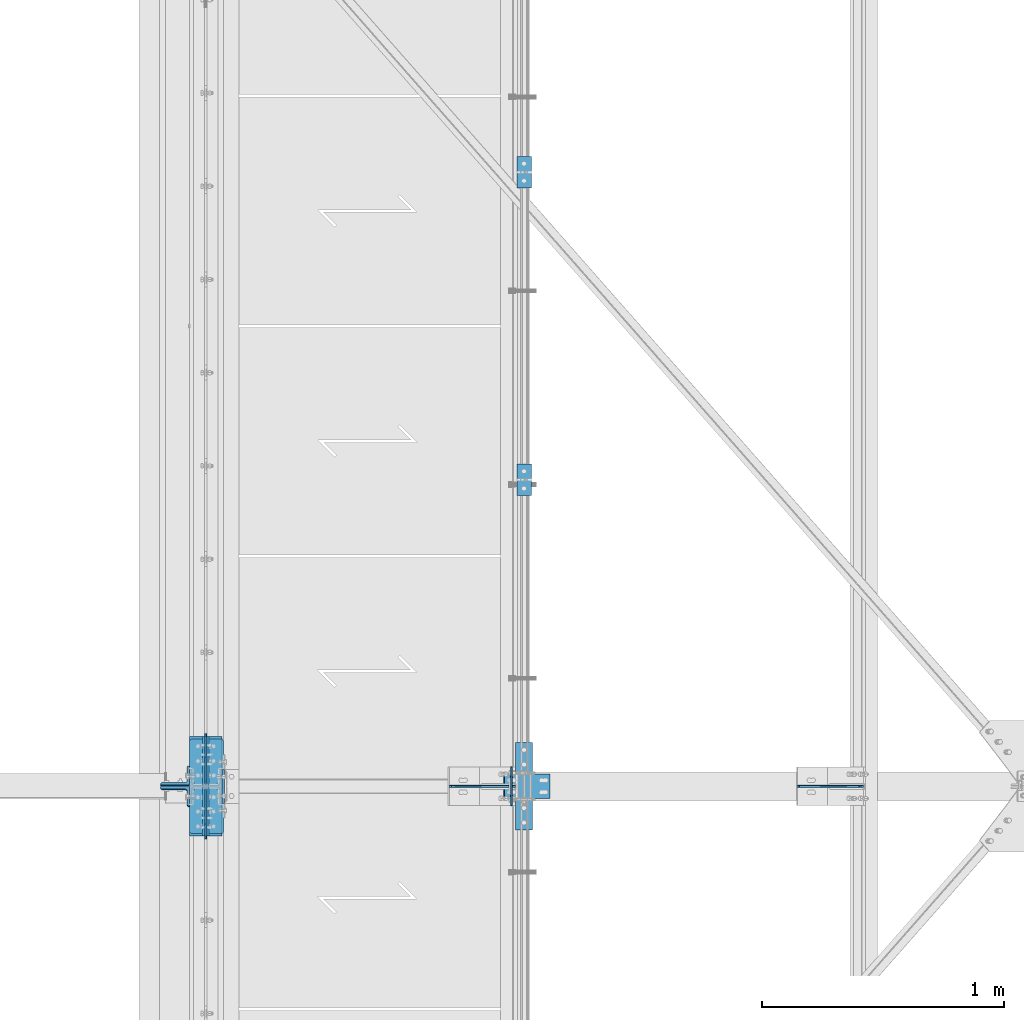
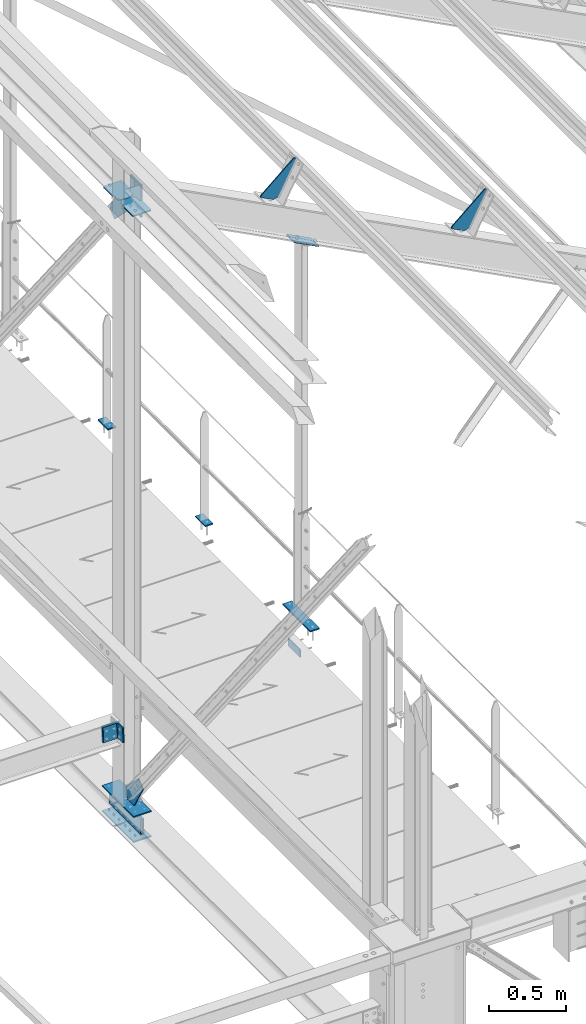
# One storey, part 71 of 496: 15 beams, 3 members, 12 elements without a shape of their own.
"""IFC2X3 building model written with IfcOpenShell, lengths in millimetres."""

from ifc_helpers import new_model, si_unit, frame, frame_2d, origin_with_axes, origin_2d_with_axis, place, context, subcontext, project, spatial, polyline, circle_curve, parameter, trimmed, segment, composite_curve, rectangle, l_section, outline, extrude, material, type_object, element, aggregate, save


model = new_model("IFC2X3")

# Units and contexts
model_context = context("Model", 3, precision=1e-05, world=origin_with_axes())
body_context = subcontext(model_context, "Body", "Model", "MODEL_VIEW")
ifc_project = project(units=[si_unit("LENGTHUNIT", "METRE", prefix="MILLI"), si_unit("AREAUNIT", "SQUARE_METRE"), si_unit("VOLUMEUNIT", "CUBIC_METRE"), si_unit("MASSUNIT", "GRAM", prefix="KILO"), si_unit("TIMEUNIT", "SECOND"), si_unit("PLANEANGLEUNIT", "RADIAN"), si_unit("SOLIDANGLEUNIT", "STERADIAN"), si_unit("THERMODYNAMICTEMPERATUREUNIT", "DEGREE_CELSIUS"), si_unit("LUMINOUSINTENSITYUNIT", "LUMEN")], contexts=[model_context])

# Site, building, storey
site_placement = place(None, origin_with_axes())
site = spatial("IfcSite", under=ifc_project, at=site_placement, CompositionType="ELEMENT")
building_placement = place(site_placement, origin_with_axes())
building = spatial("IfcBuilding", under=site, at=building_placement, Name="Undefined", CompositionType="ELEMENT")
storey_placement = place(building_placement, origin_with_axes())
storey = spatial("IfcBuildingStorey", under=building, at=storey_placement, Name="Undefined", CompositionType="ELEMENT", Elevation=0.0)

# Assembly, beams
assembly_1_placement = place(storey_placement, origin_with_axes())
assembly_1 = element("IfcElementAssembly", 1, at=assembly_1_placement, inside=storey, Name="MAIN COURANTE", AssemblyPlace="NOTDEFINED", PredefinedType="NOTDEFINED")
ifc_material = material(Name="Undefined/S235-E24")
beam_type_1 = type_object("IfcBeamType", PredefinedType="NOTDEFINED")
beam_1_placement = place(assembly_1_placement, frame((13993.9998863, 5130.00344717353, 8245.00000549095), z_axis=(-1.0, 0.0, 0.0), x_axis=(0.0, -1.0, 0.0)))
beam_1 = element("IfcBeam", 2, at=beam_1_placement, type_object=beam_type_1, material=ifc_material, context=body_context, shape_type="SweptSolid", body=[
    extrude(rectangle(XDim=10.0, YDim=60.0, at=origin_2d_with_axis()), frame((130.0, 0.0, 0.0), z_axis=(-1.0, 0.0, 0.0), x_axis=(0.0, -1.0, 0.0)), (0.0, 0.0, 1.0), 130.0),
])
beam_2_placement = place(assembly_1_placement, frame((13993.9998873551, 6400.00344717353, 8245.00000462038), z_axis=(-1.0, 0.0, 0.0), x_axis=(0.0, -1.0, 0.0)))
beam_2 = element("IfcBeam", 3, at=beam_2_placement, type_object=beam_type_1, material=ifc_material, context=body_context, shape_type="SweptSolid", body=[
    extrude(rectangle(XDim=10.0, YDim=60.0, at=origin_2d_with_axis()), frame((130.0, 0.0, 0.0), z_axis=(-1.0, 0.0, 0.0), x_axis=(0.0, -1.0, 0.0)), (0.0, 0.0, 1.0), 130.0),
])
aggregate(assembly_1, [beam_1, beam_2])

# Assembly, beam
assembly_2_placement = place(storey_placement, origin_with_axes())
assembly_2 = element("IfcElementAssembly", 4, at=assembly_2_placement, inside=storey, Name="SHED", AssemblyPlace="NOTDEFINED", PredefinedType="NOTDEFINED")
beam_type_2 = type_object("IfcBeamType", PredefinedType="NOTDEFINED")
beam_3_placement = place(assembly_2_placement, frame((15395.0613651869, 3800.0, 11158.7378432617), z_axis=(0.0, -1.0, 0.0), x_axis=(-0.886081824994261, -1.3000000762986e-08, 0.46352885499701)))
beam_3 = element("IfcBeam", 5, at=beam_3_placement, type_object=beam_type_2, material=ifc_material, context=body_context, shape_type="SweptSolid", body=[
    extrude(outline(polyline([(0.0, 0.0), (20.0, 0.0), (140.000030519084, 299.999999999567), (140.000030519153, 319.999999999545), (30.0000147075953, 319.999999999634), (0.0, 290.0), (0.0, 0.0)])), frame((0.0, 0.0, -4.0), z_axis=(0.0, 0.0, 1.0), x_axis=(1.0, 0.0, 0.0)), (0.0, 0.0, 1.0), 8.0),
])
aggregate(assembly_2, [beam_3])

assembly_3_placement = place(storey_placement, origin_with_axes())
assembly_3 = element("IfcElementAssembly", 6, at=assembly_3_placement, inside=storey, Name="SHED", AssemblyPlace="NOTDEFINED", PredefinedType="NOTDEFINED")
beam_4_placement = place(assembly_3_placement, frame((13957.7613225854, 3800.0, 11910.6201334583), z_axis=(0.0, -1.0, 0.0), x_axis=(-0.886081824994261, -1.3000000762986e-08, 0.46352885499701)))
beam_4 = element("IfcBeam", 7, at=beam_4_placement, type_object=beam_type_2, material=ifc_material, context=body_context, shape_type="SweptSolid", body=[
    extrude(outline(polyline([(0.0, 0.0), (20.0, 0.0), (140.000030519084, 299.999999999567), (140.000030519153, 319.999999999545), (30.0000147075953, 319.999999999634), (0.0, 290.0), (0.0, 0.0)])), frame((0.0, 0.0, -4.0), z_axis=(0.0, 0.0, 1.0), x_axis=(1.0, 0.0, 0.0)), (0.0, 0.0, 1.0), 8.0),
])
aggregate(assembly_3, [beam_4])

assembly_4_placement = place(storey_placement, origin_with_axes())
assembly_4 = element("IfcElementAssembly", 8, at=assembly_4_placement, inside=storey, AssemblyPlace="NOTDEFINED", PredefinedType="NOTDEFINED")
beam_type_3 = type_object("IfcBeamType", PredefinedType="NOTDEFINED")
beam_5_placement = place(assembly_4_placement, frame((12680.0, 4005.00000000017, 7055.00000000032), z_axis=(1.0, 0.0, 0.0), x_axis=(0.0, -1.0, 0.0)))
beam_5 = element("IfcBeam", 9, at=beam_5_placement, type_object=beam_type_3, material=ifc_material, context=body_context, shape_type="SweptSolid", body=[
    extrude(rectangle(XDim=10.0, YDim=133.0, at=origin_2d_with_axis()), frame((410.0, 0.0, 0.0), z_axis=(-1.0, 0.0, 0.0), x_axis=(0.0, -1.0, 0.0)), (0.0, 0.0, 1.0), 410.0),
])
aggregate(assembly_4, [beam_5])

assembly_5_placement = place(storey_placement, origin_with_axes())
assembly_5 = element("IfcElementAssembly", 10, at=assembly_5_placement, inside=storey, Name="MONTANT", AssemblyPlace="NOTDEFINED", PredefinedType="NOTDEFINED")
beam_6_placement = place(assembly_5_placement, frame((12680.0, 4005.00000000017, 7255.00000000032), z_axis=(1.0, 0.0, 0.0), x_axis=(0.0, -1.0, 0.0)))
beam_6 = element("IfcBeam", 11, at=beam_6_placement, type_object=beam_type_3, material=ifc_material, context=body_context, shape_type="SweptSolid", body=[
    extrude(rectangle(XDim=10.0, YDim=133.0, at=origin_2d_with_axis()), frame((410.0, 0.0, 0.0), z_axis=(-1.0, 0.0, 0.0), x_axis=(0.0, -1.0, 0.0)), (0.0, 0.0, 1.0), 410.0),
])

# Assembly, member
assembly_6_placement = place(storey_placement, origin_with_axes())
assembly_6 = element("IfcElementAssembly", 12, at=assembly_6_placement, inside=storey, AssemblyPlace="NOTDEFINED", PredefinedType="NOTDEFINED")
member_type_1 = type_object("IfcMemberType", PredefinedType="NOTDEFINED")
member_1_placement = place(assembly_6_placement, frame((13911.9348604257, 3800.00000001334, 11285.668922065), z_axis=(0.0, -1.0, 0.0), x_axis=(0.886081856298361, 3.500000375794e-08, -0.463528795156082)))
member_1 = element("IfcMember", 13, at=member_1_placement, type_object=member_type_1, material=ifc_material, context=body_context, shape_type="SweptSolid", body=[
    extrude(rectangle(XDim=10.0, YDim=100.0, at=origin_2d_with_axis()), frame((210.000000000491, 0.0, 1.81898940354586e-12), z_axis=(-1.0, 0.0, 0.0), x_axis=(0.0, -1.0, 0.0)), (0.0, 0.0, 1.0), 210.0),
])

# Assembly, beam
assembly_7_placement = place(storey_placement, origin_with_axes())
assembly_7 = element("IfcElementAssembly", 14, at=assembly_7_placement, inside=storey, AssemblyPlace="NOTDEFINED", PredefinedType="NOTDEFINED")
beam_type_4 = type_object("IfcBeamType", PredefinedType="NOTDEFINED")
beam_7_placement = place(assembly_7_placement, frame((13942.9998855295, 3720.0, 7985.0), z_axis=(-1.0, 0.0, 0.0), x_axis=(0.0, 0.0, 1.0)))
beam_7 = element("IfcBeam", 15, at=beam_7_placement, type_object=beam_type_4, material=ifc_material, context=body_context, shape_type="SweptSolid", body=[
    extrude(outline(polyline([(0.0, 0.0), (60.0, 0.0), (60.0, 159.999984741211), (0.0, 159.999984741211), (0.0, 0.0)])), frame((0.0, 0.0, -3.0), z_axis=(0.0, 0.0, 1.0), x_axis=(1.0, 0.0, 0.0)), (0.0, 0.0, 1.0), 6.0),
])
aggregate(assembly_7, [beam_7])

# Beam
beam_type_5 = type_object("IfcBeamType", PredefinedType="NOTDEFINED")
beam_8_placement = place(assembly_6_placement, frame((13993.9998855295, 3980.00010616247, 8245.00000367738), z_axis=(1.0, 0.0, 0.0), x_axis=(0.0, -1.0, 0.0)))
beam_8 = element("IfcBeam", 16, at=beam_8_placement, type_object=beam_type_5, material=ifc_material, context=body_context, shape_type="SweptSolid", body=[
    extrude(rectangle(XDim=10.0, YDim=70.0, at=origin_2d_with_axis()), frame((360.000000000004, 0.0, 0.0), z_axis=(-1.0, 0.0, 0.0), x_axis=(0.0, -1.0, 0.0)), (0.0, 0.0, 1.0), 360.0),
])

aggregate(assembly_6, [member_1, beam_8])

# Assembly, beam
assembly_8_placement = place(storey_placement, origin_with_axes())
assembly_8 = element("IfcElementAssembly", 17, at=assembly_8_placement, inside=storey, Name="TRAVERSE SHED", AssemblyPlace="NOTDEFINED", PredefinedType="NOTDEFINED")
beam_type_6 = type_object("IfcBeamType", PredefinedType="NOTDEFINED")
beam_9_placement = place(assembly_8_placement, frame((12751.5, 3800.0, 12161.0697488335), z_axis=(0.0, -1.0, 0.0), x_axis=(0.0, 0.0, -1.0)))
beam_9 = element("IfcBeam", 18, at=beam_9_placement, type_object=beam_type_6, material=ifc_material, context=body_context, shape_type="SweptSolid", body=[
    extrude(rectangle(XDim=10.0, YDim=140.0, at=origin_2d_with_axis()), frame((259.795359497664, 0.0, 0.0), z_axis=(-1.0, 0.0, 0.0), x_axis=(0.0, -1.0, 0.0)), (0.0, 0.0, 1.0), 259.8),
])
aggregate(assembly_8, [beam_9])

# Assembly, member
assembly_9_placement = place(storey_placement, origin_with_axes())
assembly_9 = element("IfcElementAssembly", 19, at=assembly_9_placement, inside=storey, AssemblyPlace="NOTDEFINED", PredefinedType="NOTDEFINED")
member_type_2 = type_object("IfcMemberType", PredefinedType="NOTDEFINED")
member_2_placement = place(assembly_9_placement, frame((12553.5000000005, 3844.86993295228, 7889.15200695282), z_axis=(-1.0, 0.0, 0.0), x_axis=(0.0, -0.031410887010906, -0.999506556345274)))
member_2 = element("IfcMember", 20, at=member_2_placement, type_object=member_type_2, material=ifc_material, context=body_context, shape_type="SweptSolid", body=[
    extrude(l_section(Depth=120.0, Width=80.0, Thickness=10.0, FilletRadius=11.0, EdgeRadius=5.5, at=origin_2d_with_axis()), frame((120.0, 0.0, 0.0), z_axis=(-1.0, 0.0, 0.0), x_axis=(0.0, -1.0, 0.0)), (0.0, 0.0, 1.0), 120.0),
])
aggregate(assembly_9, [member_2])

assembly_10_placement = place(storey_placement, origin_with_axes())
assembly_10 = element("IfcElementAssembly", 21, at=assembly_10_placement, inside=storey, AssemblyPlace="NOTDEFINED", PredefinedType="NOTDEFINED")
member_3_placement = place(assembly_10_placement, frame((12553.5000000006, 3755.14216197512, 7771.91261327657), z_axis=(-1.0, 0.0, 0.0), x_axis=(0.0, 0.031410887010906, 0.999506556345274)))
member_3 = element("IfcMember", 22, at=member_3_placement, type_object=member_type_2, material=ifc_material, context=body_context, shape_type="SweptSolid", body=[
    extrude(l_section(Depth=120.0, Width=80.0, Thickness=10.0, FilletRadius=11.0, EdgeRadius=5.5, at=origin_2d_with_axis()), frame((120.0, 0.0, 0.0), z_axis=(-1.0, 0.0, 0.0), x_axis=(0.0, -1.0, 0.0)), (0.0, 0.0, 1.0), 120.0),
])
aggregate(assembly_10, [member_3])

# Beam
beam_type_7 = type_object("IfcBeamType", PredefinedType="NOTDEFINED")
beam_10_placement = place(assembly_5_placement, frame((12680.0, 3797.25, 7260.0), z_axis=(-1.0, 0.0, 0.0), x_axis=(0.0, -1.0, 0.0)))
beam_10 = element("IfcBeam", 23, at=beam_10_placement, type_object=beam_type_7, material=ifc_material, context=body_context, shape_type="SweptSolid", body=[
    extrude(outline(polyline([(0.0, 20.0), (20.0, 0.0), (97.25, 0.0), (215.100128173828, 200.098342895508), (152.442047119141, 249.837310791016), (0.0, 100.0), (0.0, 20.0)])), frame((0.0, 0.0, -4.0), z_axis=(0.0, 0.0, 1.0), x_axis=(1.0, 0.0, 0.0)), (0.0, 0.0, 1.0), 8.0),
])

beam_type_8 = type_object("IfcBeamType", PredefinedType="NOTDEFINED")
beam_11_placement = place(assembly_5_placement, frame((12613.5, 3604.99692211173, 12032.0), z_axis=(0.0, 0.0, -1.0), x_axis=(0.0, 1.0, 0.0)))
beam_11 = element("IfcBeam", 24, at=beam_11_placement, type_object=beam_type_8, material=ifc_material, Name="PLAT", context=body_context, shape_type="SweptSolid", body=[
    extrude(outline(composite_curve([segment(trimmed(circle_curve(frame_2d((10.0, 10.0), x_axis=(-1.0, 0.0)), 10.0), [parameter(0.0)], [parameter(1.5707963267949)], True, "PARAMETER"), True, "CONTINUOUS"), segment(polyline([(9.99999999997453, 6.91215973347425e-11), (124.5, 0.0), (124.5, 9.0), (172.25, 9.0), (192.25, 29.0), (192.25, 104.0), (172.25, 124.0), (124.0, 124.0), (124.0, 140.0), (10.0, 140.0)]), True, "CONTINUOUS"), segment(trimmed(circle_curve(frame_2d((10.0, 130.0), x_axis=(0.0, 1.0)), 10.0), [parameter(0.0)], [parameter(1.5707963267949)], True, "PARAMETER"), True, "CONTINUOUS"), segment(polyline([(0.0, 130.0), (-1.81898940354586e-10, 10.0000000000073)]), True, "CONTINUOUS")], self_intersect=True)), frame((0.0, 0.0, -5.0), z_axis=(0.0, 0.0, 1.0), x_axis=(1.0, 0.0, 0.0)), (0.0, 0.0, 1.0), 10.0),
])

beam_12_placement = place(assembly_5_placement, frame((12613.5, 3995.0, 12032.0), z_axis=(0.0, 0.0, 1.0), x_axis=(0.0, -1.0, 0.0)))
beam_12 = element("IfcBeam", 25, at=beam_12_placement, type_object=beam_type_8, material=ifc_material, Name="PLAT", context=body_context, shape_type="SweptSolid", body=[
    extrude(outline(composite_curve([segment(trimmed(circle_curve(frame_2d((10.0, 10.0), x_axis=(-1.0, 0.0)), 10.0), [parameter(0.0)], [parameter(1.5707963267949)], True, "PARAMETER"), True, "CONTINUOUS"), segment(polyline([(9.99999999997453, 6.91215973347425e-11), (124.5, 0.0), (124.5, 9.0), (172.25, 9.0), (192.25, 29.0), (192.25, 104.0), (172.25, 124.0), (124.0, 124.0), (124.0, 140.0), (10.0, 140.0)]), True, "CONTINUOUS"), segment(trimmed(circle_curve(frame_2d((10.0, 130.0), x_axis=(0.0, 1.0)), 10.0), [parameter(0.0)], [parameter(1.5707963267949)], True, "PARAMETER"), True, "CONTINUOUS"), segment(polyline([(0.0, 130.0), (-1.81898940354586e-10, 10.0000000000073)]), True, "CONTINUOUS")], self_intersect=True)), frame((0.0, 0.0, -5.0), z_axis=(0.0, 0.0, 1.0), x_axis=(1.0, 0.0, 0.0)), (0.0, 0.0, 1.0), 10.0),
])

# Assembly, beam
assembly_11_placement = place(storey_placement, origin_with_axes())
assembly_11 = element("IfcElementAssembly", 26, at=assembly_11_placement, inside=storey, AssemblyPlace="NOTDEFINED", PredefinedType="NOTDEFINED")
beam_type_9 = type_object("IfcBeamType", PredefinedType="NOTDEFINED")
beam_13_placement = place(assembly_11_placement, frame((12688.5, 4005.00000000017, 7155.00000000032), z_axis=(0.0, 0.0, -1.0), x_axis=(0.0, -1.0, 0.0)))
beam_13 = element("IfcBeam", 27, at=beam_13_placement, type_object=beam_type_9, material=ifc_material, context=body_context, shape_type="SweptSolid", body=[
    extrude(rectangle(XDim=10.0, YDim=120.0, at=origin_2d_with_axis()), frame((410.0, 0.0, 0.0), z_axis=(-1.0, 0.0, 0.0), x_axis=(0.0, -1.0, 0.0)), (0.0, 0.0, 1.0), 410.0),
])
aggregate(assembly_11, [beam_13])

assembly_12_placement = place(storey_placement, origin_with_axes())
assembly_12 = element("IfcElementAssembly", 28, at=assembly_12_placement, inside=storey, AssemblyPlace="NOTDEFINED", PredefinedType="NOTDEFINED")
beam_14_placement = place(assembly_12_placement, frame((12671.5, 4005.00000000017, 7155.00000000032), z_axis=(0.0, 0.0, -1.0), x_axis=(0.0, -1.0, 0.0)))
beam_14 = element("IfcBeam", 29, at=beam_14_placement, type_object=beam_type_9, material=ifc_material, context=body_context, shape_type="SweptSolid", body=[
    extrude(rectangle(XDim=10.0, YDim=120.0, at=origin_2d_with_axis()), frame((410.0, 0.0, 0.0), z_axis=(-1.0, 0.0, 0.0), x_axis=(0.0, -1.0, 0.0)), (0.0, 0.0, 1.0), 410.0),
])
aggregate(assembly_12, [beam_14])

# Beam
beam_type_10 = type_object("IfcBeamType", PredefinedType="NOTDEFINED")
beam_15_placement = place(assembly_5_placement, frame((12680.0, 3802.75, 12027.0), z_axis=(-1.0, 0.0, 0.0), x_axis=(0.0, 1.0, 0.0)))
beam_15 = element("IfcBeam", 30, at=beam_15_placement, type_object=beam_type_10, material=ifc_material, context=body_context, shape_type="SweptSolid", body=[
    extrude(outline(polyline([(0.0, 20.0), (20.0, 0.0), (117.25, 0.0), (215.100280761719, 200.098205566406), (152.442230224609, 249.837203979492), (0.0, 100.0), (0.0, 20.0)])), frame((0.0, 0.0, -4.0), z_axis=(0.0, 0.0, 1.0), x_axis=(1.0, 0.0, 0.0)), (0.0, 0.0, 1.0), 8.0),
])

aggregate(assembly_5, [beam_15, beam_10, beam_6, beam_11, beam_12])

save(model, "model.ifc")
